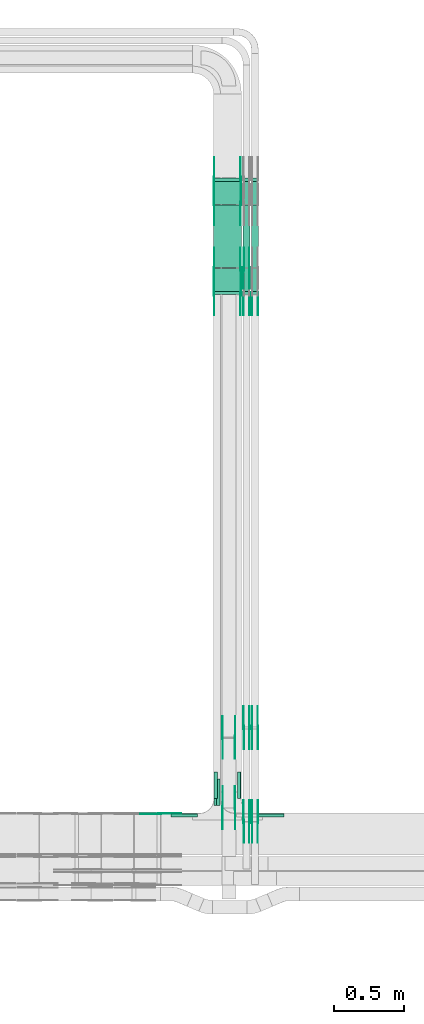
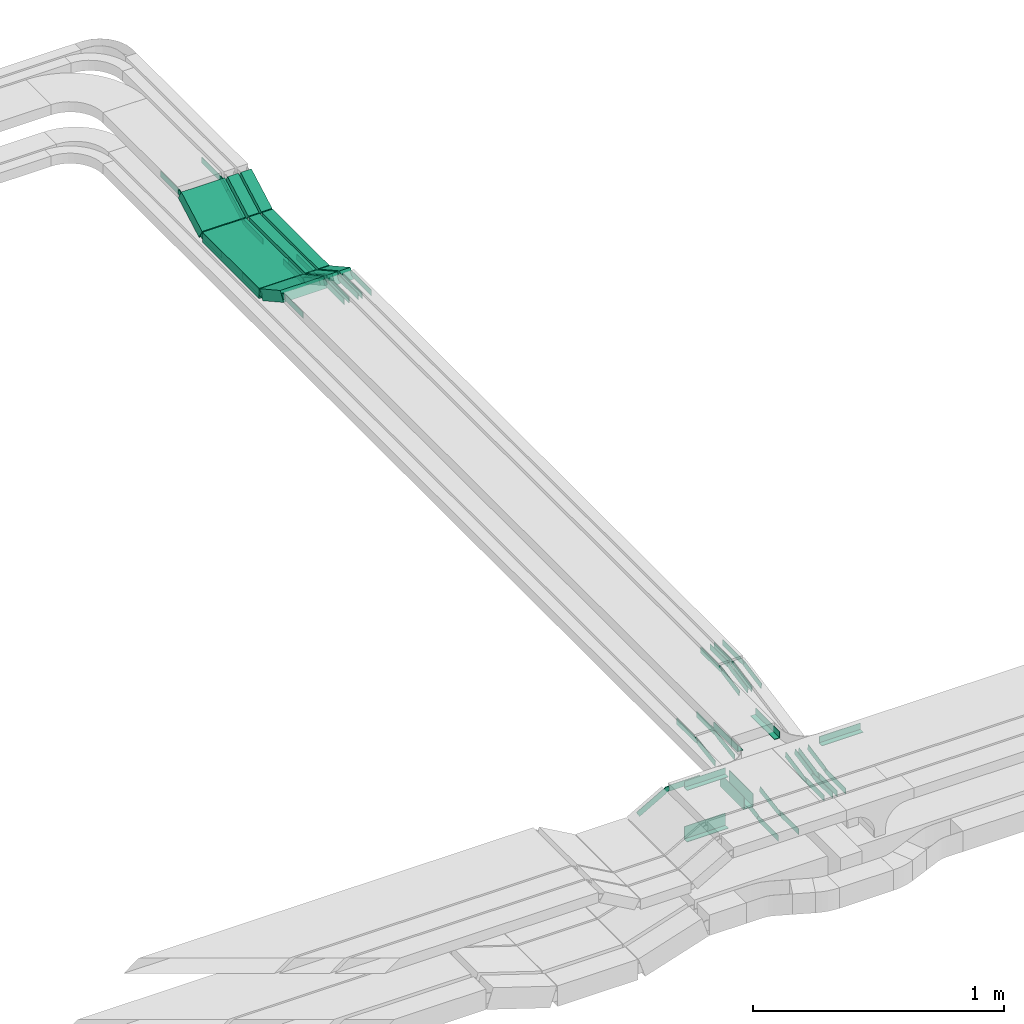
# One storey, part 13 of 27: 57 flow fittings, 9 flow segments.
"""IFC2X3 building model written with IfcOpenShell, lengths in millimetres."""

from ifc_helpers import new_model, entity, si_unit, converted_unit, derived_unit, direction, frame, frame_2d, origin, origin_2d_with_axis, place, context, subcontext, project, spatial, polyline, circle_curve, parameter, trimmed, segment, composite_curve, rectangle, outline, extrude, source, transform, mapped, material, type_object, type_shapes, element, save


model = new_model("IFC2X3")

# Units and contexts
model_context = context("Model", 3, precision=0.01, world=origin(), true_north=direction((6.12303176911189e-17, 1.0)))
body_context = subcontext(model_context, "Body", "Model", "MODEL_VIEW")
ifc_project = project(units=[si_unit("LENGTHUNIT", "METRE", prefix="MILLI"), si_unit("AREAUNIT", "SQUARE_METRE"), si_unit("VOLUMEUNIT", "CUBIC_METRE"), converted_unit("PLANEANGLEUNIT", "DEGREE", entity("IfcRatioMeasure", 0.0174532925199433), si_unit("PLANEANGLEUNIT", "RADIAN"), dimensions=[0, 0, 0, 0, 0, 0, 0]), si_unit("MASSUNIT", "GRAM", prefix="KILO"), derived_unit("MASSDENSITYUNIT", [(si_unit("MASSUNIT", "GRAM", prefix="KILO"), 1), (si_unit("LENGTHUNIT", "METRE"), -3)]), derived_unit("MOMENTOFINERTIAUNIT", [(si_unit("LENGTHUNIT", "METRE"), 4)]), si_unit("TIMEUNIT", "SECOND"), si_unit("FREQUENCYUNIT", "HERTZ"), si_unit("THERMODYNAMICTEMPERATUREUNIT", "DEGREE_CELSIUS"), derived_unit("THERMALTRANSMITTANCEUNIT", [(si_unit("MASSUNIT", "GRAM", prefix="KILO"), 1), (si_unit("THERMODYNAMICTEMPERATUREUNIT", "KELVIN"), -1), (si_unit("TIMEUNIT", "SECOND"), -3)]), derived_unit("VOLUMETRICFLOWRATEUNIT", [(si_unit("LENGTHUNIT", "METRE"), 3), (si_unit("TIMEUNIT", "SECOND"), -1)]), derived_unit("MASSFLOWRATEUNIT", [(si_unit("MASSUNIT", "GRAM", prefix="KILO"), 1), (si_unit("TIMEUNIT", "SECOND"), -1)]), derived_unit("ROTATIONALFREQUENCYUNIT", [(si_unit("TIMEUNIT", "SECOND"), -1)]), si_unit("ELECTRICCURRENTUNIT", "AMPERE"), si_unit("ELECTRICVOLTAGEUNIT", "VOLT"), si_unit("POWERUNIT", "WATT"), si_unit("FORCEUNIT", "NEWTON", prefix="KILO"), si_unit("ILLUMINANCEUNIT", "LUX"), si_unit("LUMINOUSFLUXUNIT", "LUMEN"), si_unit("LUMINOUSINTENSITYUNIT", "CANDELA"), derived_unit("USERDEFINED", [(si_unit("MASSUNIT", "GRAM", prefix="KILO"), -1), (si_unit("LENGTHUNIT", "METRE"), -2), (si_unit("TIMEUNIT", "SECOND"), 3), (si_unit("LUMINOUSFLUXUNIT", "LUMEN"), 1)]), derived_unit("LINEARVELOCITYUNIT", [(si_unit("LENGTHUNIT", "METRE"), 1), (si_unit("TIMEUNIT", "SECOND"), -1)]), si_unit("PRESSUREUNIT", "PASCAL"), derived_unit("USERDEFINED", [(si_unit("LENGTHUNIT", "METRE"), -2), (si_unit("MASSUNIT", "GRAM", prefix="KILO"), 1), (si_unit("TIMEUNIT", "SECOND"), -2)]), derived_unit("LINEARFORCEUNIT", [(si_unit("MASSUNIT", "GRAM", prefix="KILO"), 1), (si_unit("LENGTHUNIT", "METRE"), 1), (si_unit("TIMEUNIT", "SECOND"), -2), (si_unit("LENGTHUNIT", "METRE"), -1)]), derived_unit("PLANARFORCEUNIT", [(si_unit("MASSUNIT", "GRAM", prefix="KILO"), 1), (si_unit("LENGTHUNIT", "METRE"), 1), (si_unit("TIMEUNIT", "SECOND"), -2), (si_unit("LENGTHUNIT", "METRE"), -2)])], contexts=[model_context])

# Site, building, storey
site_placement = place(None, origin())
site = spatial("IfcSite", under=ifc_project, at=site_placement, CompositionType="ELEMENT")
building_placement = place(site_placement, origin())
building = spatial("IfcBuilding", under=site, at=building_placement, CompositionType="ELEMENT")
storey_placement = place(building_placement, origin())
storey = spatial("IfcBuildingStorey", under=building, at=storey_placement, CompositionType="ELEMENT", Elevation=0.0)

# Flow segments
cable_carrier_segment_type = type_object("IfcCableCarrierSegmentType", PredefinedType="CABLETRAYSEGMENT")
flow_segment_1_placement = place(storey_placement, frame((35495.11, 12636.1, 2757.26)))
element("IfcFlowSegment", 1, at=flow_segment_1_placement, inside=storey, type_object=cable_carrier_segment_type, context=body_context, shape_type="SweptSolid", body=[
    extrude(rectangle(XDim=49.9999999999987, YDim=189.266714071958, at=frame_2d((0.0, 0.0), x_axis=(0.0, 1.0))), frame((0.0, 94.89, 67.74), z_axis=(1.0, 0.0, 0.0), x_axis=(0.0, 0.874619707142013, -0.484809620241615)), (0.0, 0.0, 1.0), 199.999999999998),
])
flow_segment_2_placement = place(storey_placement, frame((35495.11, 12829.69, 2750.0)))
element("IfcFlowSegment", 2, at=flow_segment_2_placement, inside=storey, type_object=cable_carrier_segment_type, context=body_context, shape_type="SweptSolid", body=[
    extrude(rectangle(XDim=450.404775530849, YDim=199.999999999998, at=origin_2d_with_axis()), frame((100.0, 225.2, 0.0), z_axis=(0.0, 0.0, 1.0), x_axis=(0.0, 1.0, 0.0)), (0.0, 0.0, 1.0), 49.9999999999995),
])
flow_segment_3_placement = place(storey_placement, frame((35495.11, 13283.91, 2757.26)))
element("IfcFlowSegment", 3, at=flow_segment_3_placement, inside=storey, type_object=cable_carrier_segment_type, context=body_context, shape_type="SweptSolid", body=[
    extrude(rectangle(XDim=49.9999999999988, YDim=189.266714071933, at=frame_2d((0.0, 0.0), x_axis=(0.0, 1.0))), frame((0.0, 94.89, 67.74), z_axis=(1.0, 0.0, 0.0), x_axis=(0.0, -0.874619707141901, -0.484809620241818)), (0.0, 0.0, 1.0), 199.999999999998),
])
flow_segment_4_placement = place(storey_placement, frame((35707.46, 12636.1, 2757.26)))
element("IfcFlowSegment", 4, at=flow_segment_4_placement, inside=storey, type_object=cable_carrier_segment_type, context=body_context, shape_type="SweptSolid", body=[
    extrude(rectangle(XDim=49.9999999999985, YDim=49.9999999999973, at=frame_2d((0.0, 0.0), x_axis=(0.0, 1.0))), frame((25.0, 12.12, 113.62), z_axis=(0.0, 0.874619707141971, -0.484809620241692), x_axis=(-1.0, 0.0, 0.0)), (0.0, 0.0, 1.0), 189.266714071994),
])
flow_segment_5_placement = place(storey_placement, frame((35707.46, 12829.69, 2750.0)))
element("IfcFlowSegment", 5, at=flow_segment_5_placement, inside=storey, type_object=cable_carrier_segment_type, context=body_context, shape_type="SweptSolid", body=[
    extrude(rectangle(XDim=450.404775530849, YDim=49.9999999999973, at=origin_2d_with_axis()), frame((25.0, 225.2, 0.0), z_axis=(0.0, 0.0, 1.0), x_axis=(0.0, 1.0, 0.0)), (0.0, 0.0, 1.0), 49.9999999999995),
])
flow_segment_6_placement = place(storey_placement, frame((35707.46, 13283.91, 2757.26)))
element("IfcFlowSegment", 6, at=flow_segment_6_placement, inside=storey, type_object=cable_carrier_segment_type, context=body_context, shape_type="SweptSolid", body=[
    extrude(rectangle(XDim=49.9999999999974, YDim=49.9999999999973, at=origin_2d_with_axis()), frame((25.0, 12.12, 21.87), z_axis=(0.0, 0.874619707141869, 0.484809620241875), x_axis=(0.0, -0.484809620241875, 0.874619707141869)), (0.0, 0.0, 1.0), 189.266714071863),
])
flow_segment_7_placement = place(storey_placement, frame((35767.46, 12636.1, 2757.26)))
element("IfcFlowSegment", 7, at=flow_segment_7_placement, inside=storey, type_object=cable_carrier_segment_type, context=body_context, shape_type="SweptSolid", body=[
    extrude(rectangle(XDim=50.0000000000002, YDim=49.9999999999973, at=frame_2d((0.0, 0.0), x_axis=(0.0, 1.0))), frame((25.0, 12.12, 113.62), z_axis=(0.0, 0.874619707142124, -0.484809620241415), x_axis=(-1.0, 0.0, 0.0)), (0.0, 0.0, 1.0), 189.266714072121),
])
flow_segment_8_placement = place(storey_placement, frame((35767.46, 12829.69, 2750.0)))
element("IfcFlowSegment", 8, at=flow_segment_8_placement, inside=storey, type_object=cable_carrier_segment_type, context=body_context, shape_type="SweptSolid", body=[
    extrude(rectangle(XDim=450.404775530849, YDim=49.9999999999973, at=origin_2d_with_axis()), frame((25.0, 225.2, 0.0), z_axis=(0.0, 0.0, 1.0), x_axis=(0.0, 1.0, 0.0)), (0.0, 0.0, 1.0), 49.9999999999995),
])
flow_segment_9_placement = place(storey_placement, frame((35767.46, 13283.91, 2757.26)))
element("IfcFlowSegment", 9, at=flow_segment_9_placement, inside=storey, type_object=cable_carrier_segment_type, context=body_context, shape_type="SweptSolid", body=[
    extrude(rectangle(XDim=49.9999999999981, YDim=49.9999999999973, at=origin_2d_with_axis()), frame((25.0, 12.12, 21.87), z_axis=(0.0, 0.874619707141945, 0.484809620241739), x_axis=(0.0, -0.484809620241739, 0.874619707141945)), (0.0, 0.0, 1.0), 189.266714072015),
])

# Flow fittings
ifc_material_1 = material()
cable_carrier_fitting_type_1 = type_object("IfcCableCarrierFittingType", PredefinedType="NOTDEFINED", material=ifc_material_1)
shared_shape_1 = source(origin(), body_context, "Body", "SweptSolid", [
    extrude(outline(polyline([(-9.17, -21.5), (15.83, -21.5), (15.83, -19.0), (-6.67, -19.0), (-6.67, 40.5), (-9.17, 40.5), (-9.17, -21.5)])), frame((-95.0, 9.17, -26.0), z_axis=(1.0, 0.0, 0.0), x_axis=(0.0, 1.0, 0.0)), (0.0, 0.0, 1.0), 190.0),
])
type_shapes(cable_carrier_fitting_type_1, [shared_shape_1])
for number, where, z_axis, x_axis in (
    (10, (35497.61, 9070.0, 2650.0), (0.0, 0.0, 1.0), (0.0, -1.0, 0.0)),
    (11, (35542.61, 9070.0, 2650.0), (0.0, 0.0, 1.0), (0.0, 1.0, 0.0)),
):
    element("IfcFlowFitting", number, at=place(storey_placement, frame(where, z_axis=z_axis, x_axis=x_axis)), inside=storey, type_object=cable_carrier_fitting_type_1, material=ifc_material_1, context=body_context, shape_type="MappedRepresentation", body=[
        mapped(shared_shape_1, transform((0.0, 0.0, 0.0), scale=1.0)),
    ])
cable_carrier_fitting_type_2 = type_object("IfcCableCarrierFittingType", PredefinedType="NOTDEFINED", material=ifc_material_1)
shared_shape_2 = source(origin(), body_context, "Body", "SweptSolid", [
    extrude(outline(polyline([(-21.5, -9.17), (40.5, -9.17), (40.5, -6.67), (-19.0, -6.67), (-19.0, 15.83), (-21.5, 15.83), (-21.5, -9.17)])), frame((-95.0, -9.17, -26.0), z_axis=(1.0, 0.0, 0.0), x_axis=(0.0, 0.0, 1.0)), (0.0, 0.0, 1.0), 190.0),
])
type_shapes(cable_carrier_fitting_type_2, [shared_shape_2])
flow_fitting_1_placement = place(storey_placement, frame((35285.11, 8917.5, 2650.0)))
element("IfcFlowFitting", 12, at=flow_fitting_1_placement, inside=storey, type_object=cable_carrier_fitting_type_2, material=ifc_material_1, context=body_context, shape_type="MappedRepresentation", body=[
    mapped(shared_shape_2, transform((0.0, 0.0, 0.0), scale=1.0)),
])
cable_carrier_fitting_type_3 = type_object("IfcCableCarrierFittingType", PredefinedType="NOTDEFINED", material=ifc_material_1)
shared_shape_3 = source(origin(), body_context, "Body", "SweptSolid", [
    extrude(outline(polyline([(-9.17, -11.5), (15.83, -11.5), (15.83, -9.0), (-6.67, -9.0), (-6.67, 20.5), (-9.17, 20.5), (-9.17, -11.5)])), frame((-95.0, 9.17, -11.0), z_axis=(1.0, 0.0, 0.0), x_axis=(0.0, 1.0, 0.0)), (0.0, 0.0, 1.0), 190.0),
])
type_shapes(cable_carrier_fitting_type_3, [shared_shape_3])
for number, where, z_axis, x_axis in (
    (13, (35905.11, 8917.5, 2875.0), (0.0, 0.0, 1.0), (-1.0, 0.0, 0.0)),
    (14, (35497.61, 9120.0, 2875.0), (0.0, 0.0, 1.0), (0.0, -1.0, 0.0)),
    (15, (35692.61, 9120.0, 2875.0), (0.0, 0.0, 1.0), (0.0, 1.0, 0.0)),
):
    element("IfcFlowFitting", number, at=place(storey_placement, frame(where, z_axis=z_axis, x_axis=x_axis)), inside=storey, type_object=cable_carrier_fitting_type_3, material=ifc_material_1, context=body_context, shape_type="MappedRepresentation", body=[
        mapped(shared_shape_3, transform((0.0, 0.0, 0.0), scale=1.0)),
    ])
cable_carrier_fitting_type_4 = type_object("IfcCableCarrierFittingType", PredefinedType="NOTDEFINED", material=ifc_material_1)
shared_shape_4 = source(origin(), body_context, "Body", "SweptSolid", [
    extrude(outline(polyline([(-11.5, -9.17), (20.5, -9.17), (20.5, -6.67), (-9.0, -6.67), (-9.0, 15.83), (-11.5, 15.83), (-11.5, -9.17)])), frame((-95.0, -9.17, -11.0), z_axis=(1.0, 0.0, 0.0), x_axis=(0.0, 0.0, 1.0)), (0.0, 0.0, 1.0), 190.0),
])
type_shapes(cable_carrier_fitting_type_4, [shared_shape_4])
flow_fitting_2_placement = place(storey_placement, frame((35285.11, 8917.5, 2875.0)))
element("IfcFlowFitting", 16, at=flow_fitting_2_placement, inside=storey, type_object=cable_carrier_fitting_type_4, material=ifc_material_1, context=body_context, shape_type="MappedRepresentation", body=[
    mapped(shared_shape_4, transform((0.0, 0.0, 0.0), scale=1.0)),
])
ifc_material_2 = material(Name="G")
cable_carrier_fitting_type_5 = type_object("IfcCableCarrierFittingType", PredefinedType="NOTDEFINED", material=ifc_material_2)
shared_shape_5 = source(origin(), body_context, "Body", "SweptSolid", [
    extrude(outline(composite_curve([segment(trimmed(circle_curve(frame_2d((-44.59, 0.0), x_axis=(1.0, 0.0)), 12.5), [parameter(90.0000000000007)], [parameter(270.0)], True, "PARAMETER"), True, "CONTINUOUS"), segment(polyline([(-44.59, -12.5), (-33.09, -12.5)]), True, "CONTINUOUS"), segment(polyline([(-33.09, -12.5), (-31.23, -14.5)]), True, "CONTINUOUS"), segment(polyline([(-31.23, -14.5), (108.91, -14.5)]), True, "CONTINUOUS"), segment(polyline([(108.91, -14.5), (108.91, 14.5)]), True, "CONTINUOUS"), segment(polyline([(108.91, 14.5), (-31.23, 14.5)]), True, "CONTINUOUS"), segment(polyline([(-31.23, 14.5), (-33.09, 12.5)]), True, "CONTINUOUS"), segment(polyline([(-33.09, 12.5), (-44.59, 12.5)]), True, "CONTINUOUS")], self_intersect=False)), frame((44.59, 0.0, 0.0), z_axis=(0.0, 0.0, -1.0), x_axis=(1.0, 0.0, 0.0)), (0.0, 0.0, -1.0), 2.0),
])
type_shapes(cable_carrier_fitting_type_5, [shared_shape_5])
flow_fitting_3_placement = place(storey_placement, frame((35559.65, 9462.25, 2625.0), z_axis=(-1.0, 0.0, 0.0), x_axis=(0.0, 1.0, 0.0)))
element("IfcFlowFitting", 17, at=flow_fitting_3_placement, inside=storey, type_object=cable_carrier_fitting_type_5, material=ifc_material_2, context=body_context, shape_type="MappedRepresentation", body=[
    mapped(shared_shape_5, transform((0.0, 0.0, 0.0), scale=1.0)),
])
cable_carrier_fitting_type_6 = type_object("IfcCableCarrierFittingType", PredefinedType="NOTDEFINED", material=ifc_material_2)
type_shapes(cable_carrier_fitting_type_6, [shared_shape_5])
flow_fitting_4_placement = place(storey_placement, frame((35648.57, 9462.25, 2625.0), z_axis=(1.0, 0.0, 0.0), x_axis=(0.0, -0.987688340595135, -0.15643446504025)))
element("IfcFlowFitting", 18, at=flow_fitting_4_placement, inside=storey, type_object=cable_carrier_fitting_type_6, material=ifc_material_2, context=body_context, shape_type="MappedRepresentation", body=[
    mapped(shared_shape_5, transform((0.0, 0.0, 0.0), scale=1.0)),
])
flow_fitting_5_placement = place(storey_placement, frame((35559.65, 8957.89, 2545.12), z_axis=(-1.0, 0.0, 0.0), x_axis=(0.0, -1.0, 0.0)))
element("IfcFlowFitting", 19, at=flow_fitting_5_placement, inside=storey, type_object=cable_carrier_fitting_type_5, material=ifc_material_2, context=body_context, shape_type="MappedRepresentation", body=[
    mapped(shared_shape_5, transform((0.0, 0.0, 0.0), scale=1.0)),
])
flow_fitting_6_placement = place(storey_placement, frame((35648.57, 8957.89, 2545.12), z_axis=(1.0, 0.0, 0.0), x_axis=(0.0, 0.987688340597445, 0.15643446502566)))
element("IfcFlowFitting", 20, at=flow_fitting_6_placement, inside=storey, type_object=cable_carrier_fitting_type_6, material=ifc_material_2, context=body_context, shape_type="MappedRepresentation", body=[
    mapped(shared_shape_5, transform((0.0, 0.0, 0.0), scale=1.0)),
])
for number, where, z_axis, x_axis in (
    (21, (35109.14, 8915.46, 2875.0), (0.0, 1.0, 0.0), (1.0, 0.0, 0.0)),
    (22, (35499.65, 12640.79, 2875.0), (-1.0, 0.0, 0.0), (0.0, 0.874619707139365, -0.484809620246393)),
):
    element("IfcFlowFitting", number, at=place(storey_placement, frame(where, z_axis=z_axis, x_axis=x_axis)), inside=storey, type_object=cable_carrier_fitting_type_5, material=ifc_material_2, context=body_context, shape_type="MappedRepresentation", body=[
        mapped(shared_shape_5, transform((0.0, 0.0, 0.0), scale=1.0)),
    ])
flow_fitting_7_placement = place(storey_placement, frame((35688.57, 12640.79, 2875.0), z_axis=(1.0, 0.0, 0.0), x_axis=(0.0, -1.0, 0.0)))
element("IfcFlowFitting", 23, at=flow_fitting_7_placement, inside=storey, type_object=cable_carrier_fitting_type_6, material=ifc_material_2, context=body_context, shape_type="MappedRepresentation", body=[
    mapped(shared_shape_5, transform((0.0, 0.0, 0.0), scale=1.0)),
])
flow_fitting_8_placement = place(storey_placement, frame((35499.65, 12821.19, 2775.0), z_axis=(-1.0, 0.0, 0.0), x_axis=(0.0, -0.874619707139365, 0.484809620246393)))
element("IfcFlowFitting", 24, at=flow_fitting_8_placement, inside=storey, type_object=cable_carrier_fitting_type_5, material=ifc_material_2, context=body_context, shape_type="MappedRepresentation", body=[
    mapped(shared_shape_5, transform((0.0, 0.0, 0.0), scale=1.0)),
])
flow_fitting_9_placement = place(storey_placement, frame((35688.57, 12821.19, 2775.0), z_axis=(1.0, 0.0, 0.0), x_axis=(0.0, 1.0, 0.0)))
element("IfcFlowFitting", 25, at=flow_fitting_9_placement, inside=storey, type_object=cable_carrier_fitting_type_6, material=ifc_material_2, context=body_context, shape_type="MappedRepresentation", body=[
    mapped(shared_shape_5, transform((0.0, 0.0, 0.0), scale=1.0)),
])
flow_fitting_10_placement = place(storey_placement, frame((35690.57, 13469.0, 2875.0), z_axis=(1.0, 0.0, 0.0), x_axis=(0.0, -0.874619707139365, -0.484809620246393)))
element("IfcFlowFitting", 26, at=flow_fitting_10_placement, inside=storey, type_object=cable_carrier_fitting_type_5, material=ifc_material_2, context=body_context, shape_type="MappedRepresentation", body=[
    mapped(shared_shape_5, transform((0.0, 0.0, 0.0), scale=1.0)),
])
flow_fitting_11_placement = place(storey_placement, frame((35501.65, 13469.0, 2875.0), z_axis=(-1.0, 0.0, 0.0), x_axis=(0.0, 1.0, 0.0)))
element("IfcFlowFitting", 27, at=flow_fitting_11_placement, inside=storey, type_object=cable_carrier_fitting_type_6, material=ifc_material_2, context=body_context, shape_type="MappedRepresentation", body=[
    mapped(shared_shape_5, transform((0.0, 0.0, 0.0), scale=1.0)),
])
flow_fitting_12_placement = place(storey_placement, frame((35690.57, 13288.6, 2775.0), z_axis=(1.0, 0.0, 0.0), x_axis=(0.0, 0.874619707139365, 0.484809620246393)))
element("IfcFlowFitting", 28, at=flow_fitting_12_placement, inside=storey, type_object=cable_carrier_fitting_type_5, material=ifc_material_2, context=body_context, shape_type="MappedRepresentation", body=[
    mapped(shared_shape_5, transform((0.0, 0.0, 0.0), scale=1.0)),
])
flow_fitting_13_placement = place(storey_placement, frame((35501.65, 13288.6, 2775.0), z_axis=(-1.0, 0.0, 0.0), x_axis=(0.0, -1.0, 0.0)))
element("IfcFlowFitting", 29, at=flow_fitting_13_placement, inside=storey, type_object=cable_carrier_fitting_type_6, material=ifc_material_2, context=body_context, shape_type="MappedRepresentation", body=[
    mapped(shared_shape_5, transform((0.0, 0.0, 0.0), scale=1.0)),
])
flow_fitting_14_placement = place(storey_placement, frame((35712.0, 12821.19, 2775.0), z_axis=(-1.0, 0.0, 0.0), x_axis=(0.0, -0.874619707139365, 0.484809620246393)))
element("IfcFlowFitting", 30, at=flow_fitting_14_placement, inside=storey, type_object=cable_carrier_fitting_type_5, material=ifc_material_2, context=body_context, shape_type="MappedRepresentation", body=[
    mapped(shared_shape_5, transform((0.0, 0.0, 0.0), scale=1.0)),
])
flow_fitting_15_placement = place(storey_placement, frame((35750.92, 12821.19, 2775.0), z_axis=(1.0, 0.0, 0.0), x_axis=(0.0, 1.0, 0.0)))
element("IfcFlowFitting", 31, at=flow_fitting_15_placement, inside=storey, type_object=cable_carrier_fitting_type_6, material=ifc_material_2, context=body_context, shape_type="MappedRepresentation", body=[
    mapped(shared_shape_5, transform((0.0, 0.0, 0.0), scale=1.0)),
])
for number, where, z_axis, x_axis in (
    (32, (35812.92, 12640.79, 2875.0), (1.0, 0.0, 0.0), (0.0, -1.0, 0.0)),
    (33, (35812.92, 8860.26, 2746.0), (1.0, 0.0, 0.0), (0.0, 0.982105500240216, 0.188331586299048)),
):
    element("IfcFlowFitting", number, at=place(storey_placement, frame(where, z_axis=z_axis, x_axis=x_axis)), inside=storey, type_object=cable_carrier_fitting_type_5, material=ifc_material_2, context=body_context, shape_type="MappedRepresentation", body=[
        mapped(shared_shape_5, transform((0.0, 0.0, 0.0), scale=1.0)),
    ])
flow_fitting_16_placement = place(storey_placement, frame((35774.0, 8860.26, 2746.0), z_axis=(-1.0, 0.0, 0.0), x_axis=(0.0, -1.0, 0.0)))
element("IfcFlowFitting", 34, at=flow_fitting_16_placement, inside=storey, type_object=cable_carrier_fitting_type_6, material=ifc_material_2, context=body_context, shape_type="MappedRepresentation", body=[
    mapped(shared_shape_5, transform((0.0, 0.0, 0.0), scale=1.0)),
])
flow_fitting_17_placement = place(storey_placement, frame((35812.92, 9532.97, 2875.0), z_axis=(1.0, 0.0, 0.0), x_axis=(0.0, -0.982105500240216, -0.188331586299048)))
element("IfcFlowFitting", 35, at=flow_fitting_17_placement, inside=storey, type_object=cable_carrier_fitting_type_5, material=ifc_material_2, context=body_context, shape_type="MappedRepresentation", body=[
    mapped(shared_shape_5, transform((0.0, 0.0, 0.0), scale=1.0)),
])
flow_fitting_18_placement = place(storey_placement, frame((35774.0, 9532.97, 2875.0), z_axis=(-1.0, 0.0, 0.0), x_axis=(0.0, 1.0, 0.0)))
element("IfcFlowFitting", 36, at=flow_fitting_18_placement, inside=storey, type_object=cable_carrier_fitting_type_6, material=ifc_material_2, context=body_context, shape_type="MappedRepresentation", body=[
    mapped(shared_shape_5, transform((0.0, 0.0, 0.0), scale=1.0)),
])
flow_fitting_19_placement = place(storey_placement, frame((35752.92, 8860.26, 2746.0), z_axis=(1.0, 0.0, 0.0), x_axis=(0.0, 0.982105500240216, 0.188331586299048)))
element("IfcFlowFitting", 37, at=flow_fitting_19_placement, inside=storey, type_object=cable_carrier_fitting_type_5, material=ifc_material_2, context=body_context, shape_type="MappedRepresentation", body=[
    mapped(shared_shape_5, transform((0.0, 0.0, 0.0), scale=1.0)),
])
flow_fitting_20_placement = place(storey_placement, frame((35714.0, 8860.26, 2746.0), z_axis=(-1.0, 0.0, 0.0), x_axis=(0.0, -1.0, 0.0)))
element("IfcFlowFitting", 38, at=flow_fitting_20_placement, inside=storey, type_object=cable_carrier_fitting_type_6, material=ifc_material_2, context=body_context, shape_type="MappedRepresentation", body=[
    mapped(shared_shape_5, transform((0.0, 0.0, 0.0), scale=1.0)),
])
for number, where, z_axis, x_axis in (
    (39, (35752.92, 12640.79, 2875.0), (1.0, 0.0, 0.0), (0.0, -1.0, 0.0)),
    (40, (35712.0, 9532.97, 2875.0), (-1.0, 0.0, 0.0), (0.0, 1.0, 0.0)),
):
    element("IfcFlowFitting", number, at=place(storey_placement, frame(where, z_axis=z_axis, x_axis=x_axis)), inside=storey, type_object=cable_carrier_fitting_type_5, material=ifc_material_2, context=body_context, shape_type="MappedRepresentation", body=[
        mapped(shared_shape_5, transform((0.0, 0.0, 0.0), scale=1.0)),
    ])
flow_fitting_21_placement = place(storey_placement, frame((35750.92, 9532.97, 2875.0), z_axis=(1.0, 0.0, 0.0), x_axis=(0.0, -0.982105500240217, -0.188331586299042)))
element("IfcFlowFitting", 41, at=flow_fitting_21_placement, inside=storey, type_object=cable_carrier_fitting_type_6, material=ifc_material_2, context=body_context, shape_type="MappedRepresentation", body=[
    mapped(shared_shape_5, transform((0.0, 0.0, 0.0), scale=1.0)),
])
cable_carrier_fitting_type_7 = type_object("IfcCableCarrierFittingType", PredefinedType="NOTDEFINED", material=ifc_material_2)
shared_shape_6 = source(origin(), body_context, "Body", "SweptSolid", [
    extrude(outline(composite_curve([segment(trimmed(circle_curve(frame_2d((-44.59, 0.0), x_axis=(1.0, 0.0)), 12.5), [parameter(90.0000000000007)], [parameter(270.0)], True, "PARAMETER"), True, "CONTINUOUS"), segment(polyline([(-44.59, -12.5), (-33.09, -12.5)]), True, "CONTINUOUS"), segment(polyline([(-33.09, -12.5), (-31.23, -14.5)]), True, "CONTINUOUS"), segment(polyline([(-31.23, -14.5), (108.91, -14.5)]), True, "CONTINUOUS"), segment(polyline([(108.91, -14.5), (108.91, 14.5)]), True, "CONTINUOUS"), segment(polyline([(108.91, 14.5), (-31.23, 14.5)]), True, "CONTINUOUS"), segment(polyline([(-31.23, 14.5), (-33.09, 12.5)]), True, "CONTINUOUS"), segment(polyline([(-33.09, 12.5), (-44.59, 12.5)]), True, "CONTINUOUS")], self_intersect=False)), frame((44.59, 0.0, 0.0)), (0.0, 0.0, 1.0), 2.0),
])
type_shapes(cable_carrier_fitting_type_7, [shared_shape_6])
flow_fitting_22_placement = place(storey_placement, frame((35650.57, 9462.25, 2625.0), z_axis=(1.0, 0.0, 0.0), x_axis=(0.0, 1.0, 0.0)))
element("IfcFlowFitting", 42, at=flow_fitting_22_placement, inside=storey, type_object=cable_carrier_fitting_type_7, material=ifc_material_2, context=body_context, shape_type="MappedRepresentation", body=[
    mapped(shared_shape_6, transform((0.0, 0.0, 0.0), scale=1.0)),
])
cable_carrier_fitting_type_8 = type_object("IfcCableCarrierFittingType", PredefinedType="NOTDEFINED", material=ifc_material_2)
type_shapes(cable_carrier_fitting_type_8, [shared_shape_6])
flow_fitting_23_placement = place(storey_placement, frame((35561.65, 9462.25, 2625.0), z_axis=(-1.0, 0.0, 0.0), x_axis=(0.0, -0.987688340595135, -0.15643446504025)))
element("IfcFlowFitting", 43, at=flow_fitting_23_placement, inside=storey, type_object=cable_carrier_fitting_type_8, material=ifc_material_2, context=body_context, shape_type="MappedRepresentation", body=[
    mapped(shared_shape_6, transform((0.0, 0.0, 0.0), scale=1.0)),
])
flow_fitting_24_placement = place(storey_placement, frame((35650.57, 8957.89, 2545.12), z_axis=(1.0, 0.0, 0.0), x_axis=(0.0, -1.0, 0.0)))
element("IfcFlowFitting", 44, at=flow_fitting_24_placement, inside=storey, type_object=cable_carrier_fitting_type_7, material=ifc_material_2, context=body_context, shape_type="MappedRepresentation", body=[
    mapped(shared_shape_6, transform((0.0, 0.0, 0.0), scale=1.0)),
])
for number, where, z_axis, x_axis in (
    (45, (35561.65, 8957.89, 2545.12), (-1.0, 0.0, 0.0), (0.0, 0.987688340597445, 0.15643446502566)),
    (46, (35109.14, 8913.46, 2875.0), (0.0, 1.0, 0.0), (-0.869016356406542, 0.0, -0.494783358954097)),
):
    element("IfcFlowFitting", number, at=place(storey_placement, frame(where, z_axis=z_axis, x_axis=x_axis)), inside=storey, type_object=cable_carrier_fitting_type_8, material=ifc_material_2, context=body_context, shape_type="MappedRepresentation", body=[
        mapped(shared_shape_6, transform((0.0, 0.0, 0.0), scale=1.0)),
    ])
flow_fitting_25_placement = place(storey_placement, frame((35690.57, 12640.79, 2875.0), z_axis=(1.0, 0.0, 0.0), x_axis=(0.0, 0.874619707139365, -0.484809620246393)))
element("IfcFlowFitting", 47, at=flow_fitting_25_placement, inside=storey, type_object=cable_carrier_fitting_type_7, material=ifc_material_2, context=body_context, shape_type="MappedRepresentation", body=[
    mapped(shared_shape_6, transform((0.0, 0.0, 0.0), scale=1.0)),
])
flow_fitting_26_placement = place(storey_placement, frame((35501.65, 12640.79, 2875.0), z_axis=(-1.0, 0.0, 0.0), x_axis=(0.0, -1.0, 0.0)))
element("IfcFlowFitting", 48, at=flow_fitting_26_placement, inside=storey, type_object=cable_carrier_fitting_type_8, material=ifc_material_2, context=body_context, shape_type="MappedRepresentation", body=[
    mapped(shared_shape_6, transform((0.0, 0.0, 0.0), scale=1.0)),
])
flow_fitting_27_placement = place(storey_placement, frame((35690.57, 12821.19, 2775.0), z_axis=(1.0, 0.0, 0.0), x_axis=(0.0, -0.874619707139365, 0.484809620246393)))
element("IfcFlowFitting", 49, at=flow_fitting_27_placement, inside=storey, type_object=cable_carrier_fitting_type_7, material=ifc_material_2, context=body_context, shape_type="MappedRepresentation", body=[
    mapped(shared_shape_6, transform((0.0, 0.0, 0.0), scale=1.0)),
])
flow_fitting_28_placement = place(storey_placement, frame((35501.65, 12821.19, 2775.0), z_axis=(-1.0, 0.0, 0.0), x_axis=(0.0, 1.0, 0.0)))
element("IfcFlowFitting", 50, at=flow_fitting_28_placement, inside=storey, type_object=cable_carrier_fitting_type_8, material=ifc_material_2, context=body_context, shape_type="MappedRepresentation", body=[
    mapped(shared_shape_6, transform((0.0, 0.0, 0.0), scale=1.0)),
])
flow_fitting_29_placement = place(storey_placement, frame((35499.65, 13469.0, 2875.0), z_axis=(-1.0, 0.0, 0.0), x_axis=(0.0, -0.874619707139365, -0.484809620246393)))
element("IfcFlowFitting", 51, at=flow_fitting_29_placement, inside=storey, type_object=cable_carrier_fitting_type_7, material=ifc_material_2, context=body_context, shape_type="MappedRepresentation", body=[
    mapped(shared_shape_6, transform((0.0, 0.0, 0.0), scale=1.0)),
])
flow_fitting_30_placement = place(storey_placement, frame((35688.57, 13469.0, 2875.0), z_axis=(1.0, 0.0, 0.0), x_axis=(0.0, 1.0, 0.0)))
element("IfcFlowFitting", 52, at=flow_fitting_30_placement, inside=storey, type_object=cable_carrier_fitting_type_8, material=ifc_material_2, context=body_context, shape_type="MappedRepresentation", body=[
    mapped(shared_shape_6, transform((0.0, 0.0, 0.0), scale=1.0)),
])
flow_fitting_31_placement = place(storey_placement, frame((35499.65, 13288.6, 2775.0), z_axis=(-1.0, 0.0, 0.0), x_axis=(0.0, 0.874619707139365, 0.484809620246393)))
element("IfcFlowFitting", 53, at=flow_fitting_31_placement, inside=storey, type_object=cable_carrier_fitting_type_7, material=ifc_material_2, context=body_context, shape_type="MappedRepresentation", body=[
    mapped(shared_shape_6, transform((0.0, 0.0, 0.0), scale=1.0)),
])
flow_fitting_32_placement = place(storey_placement, frame((35688.57, 13288.6, 2775.0), z_axis=(1.0, 0.0, 0.0), x_axis=(0.0, -1.0, 0.0)))
element("IfcFlowFitting", 54, at=flow_fitting_32_placement, inside=storey, type_object=cable_carrier_fitting_type_8, material=ifc_material_2, context=body_context, shape_type="MappedRepresentation", body=[
    mapped(shared_shape_6, transform((0.0, 0.0, 0.0), scale=1.0)),
])
flow_fitting_33_placement = place(storey_placement, frame((35752.92, 12821.19, 2775.0), z_axis=(1.0, 0.0, 0.0), x_axis=(0.0, -0.874619707139365, 0.484809620246393)))
element("IfcFlowFitting", 55, at=flow_fitting_33_placement, inside=storey, type_object=cable_carrier_fitting_type_7, material=ifc_material_2, context=body_context, shape_type="MappedRepresentation", body=[
    mapped(shared_shape_6, transform((0.0, 0.0, 0.0), scale=1.0)),
])
flow_fitting_34_placement = place(storey_placement, frame((35714.0, 12821.19, 2775.0), z_axis=(-1.0, 0.0, 0.0), x_axis=(0.0, 1.0, 0.0)))
element("IfcFlowFitting", 56, at=flow_fitting_34_placement, inside=storey, type_object=cable_carrier_fitting_type_8, material=ifc_material_2, context=body_context, shape_type="MappedRepresentation", body=[
    mapped(shared_shape_6, transform((0.0, 0.0, 0.0), scale=1.0)),
])
for number, where, z_axis, x_axis in (
    (57, (35772.0, 12640.79, 2875.0), (-1.0, 0.0, 0.0), (0.0, -1.0, 0.0)),
    (58, (35772.0, 8860.26, 2746.0), (-1.0, 0.0, 0.0), (0.0, 0.982105500240216, 0.188331586299048)),
):
    element("IfcFlowFitting", number, at=place(storey_placement, frame(where, z_axis=z_axis, x_axis=x_axis)), inside=storey, type_object=cable_carrier_fitting_type_7, material=ifc_material_2, context=body_context, shape_type="MappedRepresentation", body=[
        mapped(shared_shape_6, transform((0.0, 0.0, 0.0), scale=1.0)),
    ])
flow_fitting_35_placement = place(storey_placement, frame((35810.92, 8860.26, 2746.0), z_axis=(1.0, 0.0, 0.0), x_axis=(0.0, -1.0, 0.0)))
element("IfcFlowFitting", 59, at=flow_fitting_35_placement, inside=storey, type_object=cable_carrier_fitting_type_8, material=ifc_material_2, context=body_context, shape_type="MappedRepresentation", body=[
    mapped(shared_shape_6, transform((0.0, 0.0, 0.0), scale=1.0)),
])
flow_fitting_36_placement = place(storey_placement, frame((35772.0, 9532.97, 2875.0), z_axis=(-1.0, 0.0, 0.0), x_axis=(0.0, -0.982105500240216, -0.188331586299048)))
element("IfcFlowFitting", 60, at=flow_fitting_36_placement, inside=storey, type_object=cable_carrier_fitting_type_7, material=ifc_material_2, context=body_context, shape_type="MappedRepresentation", body=[
    mapped(shared_shape_6, transform((0.0, 0.0, 0.0), scale=1.0)),
])
flow_fitting_37_placement = place(storey_placement, frame((35810.92, 9532.97, 2875.0), z_axis=(1.0, 0.0, 0.0), x_axis=(0.0, 1.0, 0.0)))
element("IfcFlowFitting", 61, at=flow_fitting_37_placement, inside=storey, type_object=cable_carrier_fitting_type_8, material=ifc_material_2, context=body_context, shape_type="MappedRepresentation", body=[
    mapped(shared_shape_6, transform((0.0, 0.0, 0.0), scale=1.0)),
])
flow_fitting_38_placement = place(storey_placement, frame((35712.0, 8860.26, 2746.0), z_axis=(-1.0, 0.0, 0.0), x_axis=(0.0, 0.982105500240216, 0.188331586299048)))
element("IfcFlowFitting", 62, at=flow_fitting_38_placement, inside=storey, type_object=cable_carrier_fitting_type_7, material=ifc_material_2, context=body_context, shape_type="MappedRepresentation", body=[
    mapped(shared_shape_6, transform((0.0, 0.0, 0.0), scale=1.0)),
])
flow_fitting_39_placement = place(storey_placement, frame((35750.92, 8860.26, 2746.0), z_axis=(1.0, 0.0, 0.0), x_axis=(0.0, -1.0, 0.0)))
element("IfcFlowFitting", 63, at=flow_fitting_39_placement, inside=storey, type_object=cable_carrier_fitting_type_8, material=ifc_material_2, context=body_context, shape_type="MappedRepresentation", body=[
    mapped(shared_shape_6, transform((0.0, 0.0, 0.0), scale=1.0)),
])
for number, where, z_axis, x_axis in (
    (64, (35712.0, 12640.79, 2875.0), (-1.0, 0.0, 0.0), (0.0, -1.0, 0.0)),
    (65, (35752.92, 9532.97, 2875.0), (1.0, 0.0, 0.0), (0.0, 1.0, 0.0)),
):
    element("IfcFlowFitting", number, at=place(storey_placement, frame(where, z_axis=z_axis, x_axis=x_axis)), inside=storey, type_object=cable_carrier_fitting_type_7, material=ifc_material_2, context=body_context, shape_type="MappedRepresentation", body=[
        mapped(shared_shape_6, transform((0.0, 0.0, 0.0), scale=1.0)),
    ])
flow_fitting_40_placement = place(storey_placement, frame((35714.0, 9532.97, 2875.0), z_axis=(-1.0, 0.0, 0.0), x_axis=(0.0, -0.982105500240217, -0.188331586299042)))
element("IfcFlowFitting", 66, at=flow_fitting_40_placement, inside=storey, type_object=cable_carrier_fitting_type_8, material=ifc_material_2, context=body_context, shape_type="MappedRepresentation", body=[
    mapped(shared_shape_6, transform((0.0, 0.0, 0.0), scale=1.0)),
])

save(model, "model.ifc")
